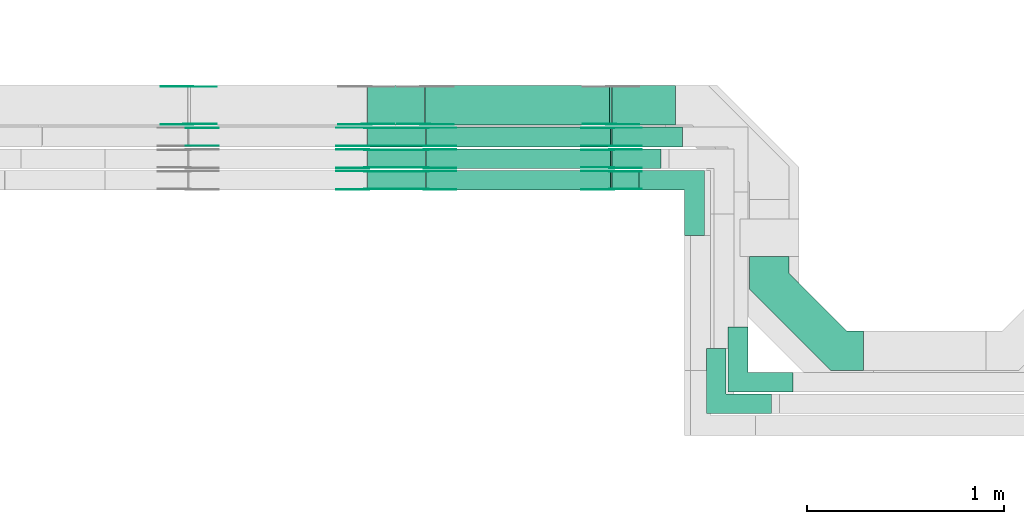
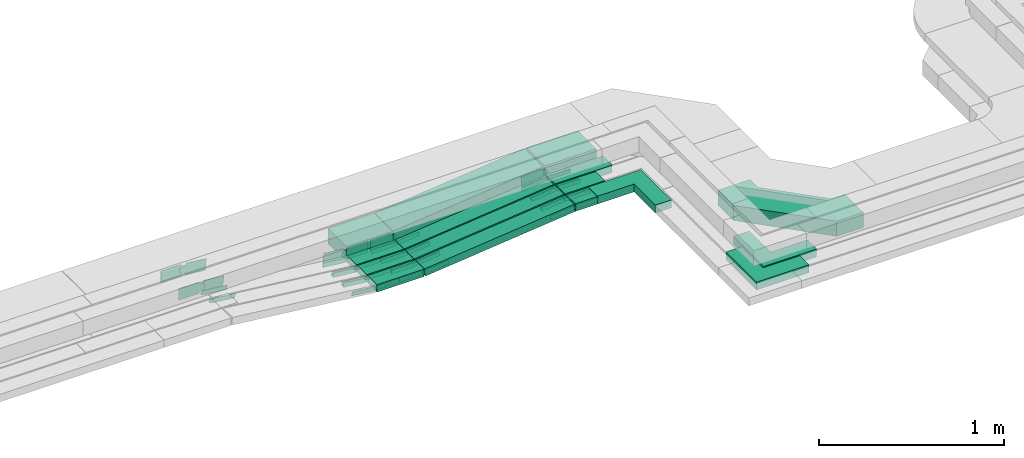
# One storey, part 19 of 33: 52 flow fittings, 12 flow segments.
"""IFC2X3 building model written with IfcOpenShell, lengths in millimetres."""

from ifc_helpers import new_model, entity, si_unit, converted_unit, derived_unit, direction, frame, frame_2d, origin, origin_2d_with_axis, place, context, subcontext, project, spatial, polyline, circle_curve, parameter, trimmed, segment, composite_curve, rectangle, outline, extrude, source, transform, mapped, material, type_object, type_shapes, element, save


model = new_model("IFC2X3")

# Units and contexts
model_context = context("Model", 3, precision=0.01, world=origin(), true_north=direction((6.12303176911189e-17, 1.0)))
body_context = subcontext(model_context, "Body", "Model", "MODEL_VIEW")
ifc_project = project(units=[si_unit("LENGTHUNIT", "METRE", prefix="MILLI"), si_unit("AREAUNIT", "SQUARE_METRE"), si_unit("VOLUMEUNIT", "CUBIC_METRE"), converted_unit("PLANEANGLEUNIT", "DEGREE", entity("IfcRatioMeasure", 0.0174532925199433), si_unit("PLANEANGLEUNIT", "RADIAN"), dimensions=[0, 0, 0, 0, 0, 0, 0]), si_unit("MASSUNIT", "GRAM", prefix="KILO"), derived_unit("MASSDENSITYUNIT", [(si_unit("MASSUNIT", "GRAM", prefix="KILO"), 1), (si_unit("LENGTHUNIT", "METRE"), -3)]), derived_unit("MOMENTOFINERTIAUNIT", [(si_unit("LENGTHUNIT", "METRE"), 4)]), si_unit("TIMEUNIT", "SECOND"), si_unit("FREQUENCYUNIT", "HERTZ"), si_unit("THERMODYNAMICTEMPERATUREUNIT", "DEGREE_CELSIUS"), derived_unit("THERMALTRANSMITTANCEUNIT", [(si_unit("MASSUNIT", "GRAM", prefix="KILO"), 1), (si_unit("THERMODYNAMICTEMPERATUREUNIT", "KELVIN"), -1), (si_unit("TIMEUNIT", "SECOND"), -3)]), derived_unit("VOLUMETRICFLOWRATEUNIT", [(si_unit("LENGTHUNIT", "METRE"), 3), (si_unit("TIMEUNIT", "SECOND"), -1)]), derived_unit("MASSFLOWRATEUNIT", [(si_unit("MASSUNIT", "GRAM", prefix="KILO"), 1), (si_unit("TIMEUNIT", "SECOND"), -1)]), derived_unit("ROTATIONALFREQUENCYUNIT", [(si_unit("TIMEUNIT", "SECOND"), -1)]), si_unit("ELECTRICCURRENTUNIT", "AMPERE"), si_unit("ELECTRICVOLTAGEUNIT", "VOLT"), si_unit("POWERUNIT", "WATT"), si_unit("FORCEUNIT", "NEWTON", prefix="KILO"), si_unit("ILLUMINANCEUNIT", "LUX"), si_unit("LUMINOUSFLUXUNIT", "LUMEN"), si_unit("LUMINOUSINTENSITYUNIT", "CANDELA"), derived_unit("USERDEFINED", [(si_unit("MASSUNIT", "GRAM", prefix="KILO"), -1), (si_unit("LENGTHUNIT", "METRE"), -2), (si_unit("TIMEUNIT", "SECOND"), 3), (si_unit("LUMINOUSFLUXUNIT", "LUMEN"), 1)]), derived_unit("LINEARVELOCITYUNIT", [(si_unit("LENGTHUNIT", "METRE"), 1), (si_unit("TIMEUNIT", "SECOND"), -1)]), si_unit("PRESSUREUNIT", "PASCAL"), derived_unit("USERDEFINED", [(si_unit("LENGTHUNIT", "METRE"), -2), (si_unit("MASSUNIT", "GRAM", prefix="KILO"), 1), (si_unit("TIMEUNIT", "SECOND"), -2)]), derived_unit("LINEARFORCEUNIT", [(si_unit("MASSUNIT", "GRAM", prefix="KILO"), 1), (si_unit("LENGTHUNIT", "METRE"), 1), (si_unit("TIMEUNIT", "SECOND"), -2), (si_unit("LENGTHUNIT", "METRE"), -1)]), derived_unit("PLANARFORCEUNIT", [(si_unit("MASSUNIT", "GRAM", prefix="KILO"), 1), (si_unit("LENGTHUNIT", "METRE"), 1), (si_unit("TIMEUNIT", "SECOND"), -2), (si_unit("LENGTHUNIT", "METRE"), -2)])], contexts=[model_context])

# Site, building, storey
site_placement = place(None, frame((0.0, -0.00077364408347762, 0.0)))
site = spatial("IfcSite", under=ifc_project, at=site_placement, CompositionType="ELEMENT")
building_placement = place(site_placement, origin())
building = spatial("IfcBuilding", under=site, at=building_placement, CompositionType="ELEMENT")
storey_placement = place(building_placement, frame((0.0, 0.0, 8100.0)))
storey = spatial("IfcBuildingStorey", under=building, at=storey_placement, CompositionType="ELEMENT", Elevation=8100.0)

# Flow segments
cable_carrier_segment_type = type_object("IfcCableCarrierSegmentType", PredefinedType="CABLETRAYSEGMENT")
flow_segment_1_placement = place(storey_placement, frame((42299.7266757616, 9974.9985534668, 2547.39498136109)))
element("IfcFlowSegment", 1, at=flow_segment_1_placement, inside=storey, type_object=cable_carrier_segment_type, context=body_context, shape_type="SweptSolid", body=[
    extrude(rectangle(XDim=321.461786684155, YDim=200.000000000002, at=frame_2d((0.0, -1.08713038571295e-12), x_axis=(1.0, 0.0))), frame((160.730893342077, 100.0, 0.0), z_axis=(0.0, 0.0, 1.0), x_axis=(-1.0, 0.0, 0.0)), (0.0, 0.0, 1.0), 99.9999999999989),
])
flow_segment_2_placement = place(storey_placement, frame((42299.9057283488, 9864.99855353356, 2544.9587837225)))
element("IfcFlowSegment", 2, at=flow_segment_2_placement, inside=storey, type_object=cable_carrier_segment_type, context=body_context, shape_type="SweptSolid", body=[
    extrude(rectangle(XDim=357.279766558546, YDim=99.9999998664901, at=frame_2d((-4.33431068813661e-12, 1.08357767203415e-12), x_axis=(1.0, 0.0))), frame((178.639882016923, 50.0, 0.0212370079798916), z_axis=(0.000118881671848944, 0.0, 0.999999992933574), x_axis=(-0.999999992933574, 0.0, 0.000118881671848944)), (0.0, 0.0, 1.0), 49.9999999332506),
])
flow_segment_3_placement = place(storey_placement, frame((42299.7266757616, 9754.9985534668, 2546.31908538351)))
element("IfcFlowSegment", 3, at=flow_segment_3_placement, inside=storey, type_object=cable_carrier_segment_type, context=body_context, shape_type="SweptSolid", body=[
    extrude(rectangle(XDim=247.461786684189, YDim=99.9999999999989, at=origin_2d_with_axis()), frame((123.730893342094, 50.0, 0.0), z_axis=(0.0, 0.0, 1.0), x_axis=(-1.0, 0.0, 0.0)), (0.0, 0.0, 1.0), 50.0000000000016),
])
flow_segment_4_placement = place(storey_placement, frame((41059.7844054956, 9644.99855346679, 2446.66940793269)))
element("IfcFlowSegment", 4, at=flow_segment_4_placement, inside=storey, type_object=cable_carrier_segment_type, context=body_context, shape_type="SweptSolid", body=[
    extrude(rectangle(XDim=294.865843634582, YDim=100.000000000001, at=origin_2d_with_axis()), frame((147.432921817291, 50.0, 0.0), z_axis=(0.0, 0.0, 1.0), x_axis=(-1.0, 0.0, 0.0)), (0.0, 0.0, 1.0), 50.0000000000016),
])
flow_segment_5_placement = place(storey_placement, frame((42299.7266757616, 9644.99855346679, 2546.66940793271)))
element("IfcFlowSegment", 5, at=flow_segment_5_placement, inside=storey, type_object=cable_carrier_segment_type, context=body_context, shape_type="SweptSolid", body=[
    extrude(rectangle(XDim=137.461786684197, YDim=100.000000000001, at=frame_2d((0.0, 1.08357767203415e-12), x_axis=(1.0, 0.0))), frame((68.7308933420983, 50.0, 0.0), z_axis=(0.0, 0.0, 1.0), x_axis=(-1.0, 0.0, 0.0)), (0.0, 0.0, 1.0), 49.9999999999995),
])
flow_segment_6_placement = place(storey_placement, frame((41357.0677822618, 9644.99855346682, 2447.07819267562)))
element("IfcFlowSegment", 6, at=flow_segment_6_placement, inside=storey, type_object=cable_carrier_segment_type, context=body_context, shape_type="SweptSolid", body=[
    extrude(rectangle(XDim=49.999999999999, YDim=100.000000000001, at=origin_2d_with_axis()), frame((2.64465136483404, 50.0, 24.8597228294773), z_axis=(0.994388913179111, 0.0, 0.105786054593537), x_axis=(-0.105786054593537, 0.0, 0.994388913179111)), (0.0, 0.0, 1.0), 940.227757215781),
])
flow_segment_7_placement = place(storey_placement, frame((41059.7844054956, 9754.99855346682, 2446.32300573429)))
element("IfcFlowSegment", 7, at=flow_segment_7_placement, inside=storey, type_object=cable_carrier_segment_type, context=body_context, shape_type="SweptSolid", body=[
    extrude(rectangle(XDim=294.902694932285, YDim=99.9999999999989, at=origin_2d_with_axis()), frame((147.451347466142, 50.0, 0.0), z_axis=(0.0, 0.0, 1.0), x_axis=(-1.0, 0.0, 0.0)), (0.0, 0.0, 1.0), 50.0000000000016),
])
flow_segment_8_placement = place(storey_placement, frame((41357.1046335595, 9754.99855346682, 2446.73179047722)))
element("IfcFlowSegment", 8, at=flow_segment_8_placement, inside=storey, type_object=cable_carrier_segment_type, context=body_context, shape_type="SweptSolid", body=[
    extrude(rectangle(XDim=49.9999999999999, YDim=99.9999999999989, at=origin_2d_with_axis()), frame((2.64465136483404, 50.0, 24.8597228294773), z_axis=(0.994388913179093, 0.0, 0.105786054593709), x_axis=(-0.105786054593709, 0.0, 0.994388913179093)), (0.0, 0.0, 1.0), 940.190697975519),
])
flow_segment_9_placement = place(storey_placement, frame((41059.5981585347, 9864.99855346682, 2444.98237905461)))
element("IfcFlowSegment", 9, at=flow_segment_9_placement, inside=storey, type_object=cable_carrier_segment_type, context=body_context, shape_type="SweptSolid", body=[
    extrude(rectangle(XDim=295.052090595501, YDim=99.9999999999989, at=origin_2d_with_axis()), frame((147.526045297751, 50.0, 0.0), z_axis=(0.0, 0.0, 1.0), x_axis=(-1.0, 0.0, 0.0)), (0.0, 0.0, 1.0), 50.0000000000016),
])
flow_segment_10_placement = place(storey_placement, frame((41357.0677822617, 9864.99855346682, 2445.39116379754)))
element("IfcFlowSegment", 10, at=flow_segment_10_placement, inside=storey, type_object=cable_carrier_segment_type, context=body_context, shape_type="SweptSolid", body=[
    extrude(rectangle(XDim=49.9999999999999, YDim=99.9999999999989, at=origin_2d_with_axis()), frame((2.64465136484271, 50.0, 24.8597228294751), z_axis=(0.994388913179093, 0.0, 0.105786054593709), x_axis=(-0.105786054593709, 0.0, 0.994388913179093)), (0.0, 0.0, 1.0), 940.407341948837),
])
flow_segment_11_placement = place(storey_placement, frame((41059.7844054956, 9974.99855346681, 2447.10630735317)))
element("IfcFlowSegment", 11, at=flow_segment_11_placement, inside=storey, type_object=cable_carrier_segment_type, context=body_context, shape_type="SweptSolid", body=[
    extrude(rectangle(XDim=289.500216036665, YDim=199.999999999998, at=origin_2d_with_axis()), frame((144.750108018333, 100.0, 0.0), z_axis=(0.0, 0.0, 1.0), x_axis=(-1.0, 0.0, 0.0)), (0.0, 0.0, 1.0), 99.9999999999989),
])
flow_segment_12_placement = place(storey_placement, frame((41351.7021546638, 9974.99855346681, 2447.79564643714)))
element("IfcFlowSegment", 12, at=flow_segment_12_placement, inside=storey, type_object=cable_carrier_segment_type, context=body_context, shape_type="SweptSolid", body=[
    extrude(rectangle(XDim=99.999999999998, YDim=199.999999999998, at=origin_2d_with_axis()), frame((5.28930272967675, 100.0, 49.7194456589545), z_axis=(0.994388913179111, 0.0, 0.105786054593537), x_axis=(-0.105786054593537, 0.0, 0.994388913179111)), (0.0, 0.0, 1.0), 940.304512766153),
])

# Flow fittings
ifc_material_1 = material()
cable_carrier_fitting_type_1 = type_object("IfcCableCarrierFittingType", Name="470_DKC_G5_Sheet horizontal bend:-", PredefinedType="NOTDEFINED", material=ifc_material_1)
shared_shape_1 = source(origin(), body_context, "Body", "SweptSolid", [
    extrude(outline(polyline([(-269.5, -306.499999999999), (-102.07864376269, -306.499999999999), (306.499999999999, 102.07864376269), (306.5, 269.499999999999), (106.5, 269.499999999999), (106.5, 184.921356237309), (-184.921356237309, -106.499999999999), (-269.5, -106.499999999999), (-269.5, -306.499999999999)])), frame((-206.499999999993, 206.499999999989, -50.0)), (0.0, 0.0, 1.0), 100.0),
])
type_shapes(cable_carrier_fitting_type_1, [shared_shape_1])
flow_fitting_placement = place(storey_placement, frame((43097.1884624458, 8832.6896027525, 2597.39498136109), z_axis=(0.0, 0.0, 1.0), x_axis=(0.0, -1.0, 0.0)))
element("IfcFlowFitting", 13, at=flow_fitting_placement, inside=storey, type_object=cable_carrier_fitting_type_1, material=ifc_material_1, Name="470_DKC_G5_Sheet horizontal bend:-", ObjectType="470_DKC_G5_Sheet horizontal bend:-", context=body_context, shape_type="MappedRepresentation", body=[
    mapped(shared_shape_1, transform((0.0, 0.0, 0.0), scale=1.0)),
])
cable_carrier_fitting_type_2 = type_object("IfcCableCarrierFittingType", Name="470_DKC_F5_Mesh horizontal angle:At right angles", PredefinedType="NOTDEFINED", material=ifc_material_1)
shared_shape_2 = source(origin(), body_context, "Body", "SweptSolid", [
    extrude(outline(polyline([(-143.333333333335, -143.333333333332), (186.666666666646, -143.333333333332), (186.666666666652, -43.3333333333317), (-43.3333333333294, -43.3333333333373), (-43.3333333333166, 186.666666666663), (-143.333333333317, 186.666666666669), (-143.333333333335, -143.333333333332)])), frame((-93.3333333333341, 93.3333333333192, -25.0), z_axis=(0.0, 0.0, 1.0), x_axis=(0.0, 1.0, 0.0)), (0.0, 0.0, 1.0), 51.9999999999999),
])
type_shapes(cable_carrier_fitting_type_2, [shared_shape_2])
for number, where, z_axis, x_axis, name in (
    (14, (42937.1884624458, 8672.68960275251, 2569.92549664435), (0.0, 0.0, 1.0), (0.0, -1.0, 0.0), "470_DKC_F5_Mesh horizontal angle:At right angles"),
    (15, (42827.1884624458, 8562.68960275251, 2571.31908538351), (0.0, 0.0, 1.0), (0.0, -1.0, 0.0), "470_DKC_F5_Mesh horizontal angle:At right angles"),
    (16, (42717.1884624458, 9694.9985534668, 2571.66940793271), (0.0, 0.0, 1.0), (0.0, 1.0, 0.0), "470_DKC_F5_Mesh horizontal angle:At right angles"),
):
    element("IfcFlowFitting", number, at=place(storey_placement, frame(where, z_axis=z_axis, x_axis=x_axis)), inside=storey, type_object=cable_carrier_fitting_type_2, material=ifc_material_1, Name=name, ObjectType="470_DKC_F5_Mesh horizontal angle:At right angles", context=body_context, shape_type="MappedRepresentation", body=[
        mapped(shared_shape_2, transform((0.0, 0.0, 0.0), scale=1.0)),
    ])
ifc_material_2 = material(Name="G")
cable_carrier_fitting_type_3 = type_object("IfcCableCarrierFittingType", PredefinedType="NOTDEFINED", material=ifc_material_2)
shared_shape_3 = source(origin(), body_context, "Body", "SweptSolid", [
    extrude(outline(composite_curve([segment(trimmed(circle_curve(frame_2d((-44.5901162790698, 0.0), x_axis=(1.0, 0.0)), 12.5), [parameter(90.0000000000007)], [parameter(270.0)], True, "PARAMETER"), True, "CONTINUOUS"), segment(polyline([(-44.5901162790697, -12.5), (-33.0901162790698, -12.5)]), True, "CONTINUOUS"), segment(polyline([(-33.0901162790698, -12.5), (-31.2296511627907, -14.5)]), True, "CONTINUOUS"), segment(polyline([(-31.2296511627907, -14.5), (108.90988372093, -14.5)]), True, "CONTINUOUS"), segment(polyline([(108.90988372093, -14.5), (108.90988372093, 14.5)]), True, "CONTINUOUS"), segment(polyline([(108.90988372093, 14.5), (-31.2296511627907, 14.5)]), True, "CONTINUOUS"), segment(polyline([(-31.2296511627907, 14.5), (-33.0901162790698, 12.5)]), True, "CONTINUOUS"), segment(polyline([(-33.0901162790698, 12.5), (-44.5901162790699, 12.5)]), True, "CONTINUOUS")], self_intersect=False)), frame((44.5901162790698, 0.0, 0.0), z_axis=(0.0, 0.0, -1.0), x_axis=(1.0, 0.0, 0.0)), (0.0, 0.0, -1.0), 2.0),
])
type_shapes(cable_carrier_fitting_type_3, [shared_shape_3])
for number, where, z_axis, x_axis in (
    (17, (42297.1884624458, 9649.53855345666, 2571.66940793272), (0.0, -1.0, 0.0), (-0.994388913179106, 0.0, -0.105786054593584)),
    (18, (41357.188462446, 9649.53855345666, 2471.66940793268), (0.0, -1.0, 0.0), (0.994388913179106, 0.0, 0.105786054593584)),
    (19, (41057.1884624458, 9740.45855347695, 2471.66940793268), (0.0, 1.0, 0.0), (-0.993961132894515, 0.0, 0.10973270385374)),
    (20, (41357.2253137437, 9759.53855345666, 2471.32300573428), (0.0, -1.0, 0.0), (0.994388913179106, 0.0, 0.105786054593584)),
    (21, (41057.1884624458, 9850.45855347697, 2471.32300573428), (0.0, 1.0, 0.0), (-0.993961132894515, 0.0, 0.10973270385374)),
    (22, (41357.188462446, 9869.53855345666, 2469.9823790546), (0.0, -1.0, 0.0), (0.994388913179106, 0.0, 0.105786054593584)),
    (23, (41057.0022154848, 9960.45855347698, 2469.9823790546), (0.0, 1.0, 0.0), (-0.993961132894515, 0.0, 0.10973270385374)),
    (24, (42297.1884624458, 9850.45855347697, 2571.31908538353), (0.0, 1.0, 0.0), (1.0, 0.0, 0.0)),
    (25, (42297.3687584532, 9960.45855347698, 2570.00155948099), (0.0, 1.0, 0.0), (0.999999992933574, 0.0, -0.000118881671840432)),
):
    element("IfcFlowFitting", number, at=place(storey_placement, frame(where, z_axis=z_axis, x_axis=x_axis)), inside=storey, type_object=cable_carrier_fitting_type_3, material=ifc_material_2, context=body_context, shape_type="MappedRepresentation", body=[
        mapped(shared_shape_3, transform((0.0, 0.0, 0.0), scale=1.0)),
    ])
cable_carrier_fitting_type_4 = type_object("IfcCableCarrierFittingType", PredefinedType="NOTDEFINED", material=ifc_material_2)
shared_shape_4 = source(origin(), body_context, "Body", "SweptSolid", [
    extrude(outline(composite_curve([segment(trimmed(circle_curve(frame_2d((-44.5901162790697, 0.0), x_axis=(1.0, 0.0)), 12.5), [parameter(90.0000000000007)], [parameter(270.0)], True, "PARAMETER"), True, "CONTINUOUS"), segment(polyline([(-44.5901162790697, -12.5), (-33.0901162790697, -12.5)]), True, "CONTINUOUS"), segment(polyline([(-33.0901162790697, -12.5), (-31.2296511627907, -14.5)]), True, "CONTINUOUS"), segment(polyline([(-31.2296511627907, -14.5), (108.90988372093, -14.5)]), True, "CONTINUOUS"), segment(polyline([(108.90988372093, -14.5), (108.90988372093, 14.5)]), True, "CONTINUOUS"), segment(polyline([(108.90988372093, 14.5), (-31.2296511627907, 14.5)]), True, "CONTINUOUS"), segment(polyline([(-31.2296511627907, 14.5), (-33.0901162790698, 12.5)]), True, "CONTINUOUS"), segment(polyline([(-33.0901162790698, 12.5), (-44.5901162790699, 12.5)]), True, "CONTINUOUS")], self_intersect=False)), frame((44.5901162790697, 0.0, 0.0)), (0.0, 0.0, 1.0), 2.0),
])
type_shapes(cable_carrier_fitting_type_4, [shared_shape_4])
for number, where, z_axis, x_axis in (
    (26, (42297.1884624458, 9740.45855347698, 2571.66940793273), (0.0, 1.0, 0.0), (-0.994388913179106, 0.0, -0.105786054593584)),
    (27, (41357.188462446, 9740.45855347698, 2471.66940793267), (0.0, 1.0, 0.0), (0.994388913179106, 0.0, 0.105786054593584)),
    (28, (41057.1884624458, 9649.53855345663, 2471.66940793268), (0.0, -1.0, 0.0), (-0.993961132894515, 0.0, 0.10973270385374)),
    (29, (41357.2253137437, 9850.45855347698, 2471.32300573428), (0.0, 1.0, 0.0), (0.994388913179106, 0.0, 0.105786054593584)),
    (30, (41057.1884624458, 9759.53855345666, 2471.32300573428), (0.0, -1.0, 0.0), (-0.993961132894515, 0.0, 0.10973270385374)),
    (31, (41357.188462446, 9960.45855347698, 2469.9823790546), (0.0, 1.0, 0.0), (0.994388913179106, 0.0, 0.105786054593584)),
    (32, (41057.0022154848, 9869.53855345666, 2469.9823790546), (0.0, -1.0, 0.0), (-0.993961132894515, 0.0, 0.10973270385374)),
    (33, (42297.1884624458, 9759.53855345666, 2571.31908538354), (0.0, -1.0, 0.0), (1.0, 0.0, 0.0)),
    (34, (42297.3687584532, 9869.53855345666, 2570.00155948099), (0.0, -1.0, 0.0), (0.999999992933574, 0.0, -0.000118881671840432)),
):
    element("IfcFlowFitting", number, at=place(storey_placement, frame(where, z_axis=z_axis, x_axis=x_axis)), inside=storey, type_object=cable_carrier_fitting_type_4, material=ifc_material_2, context=body_context, shape_type="MappedRepresentation", body=[
        mapped(shared_shape_4, transform((0.0, 0.0, 0.0), scale=1.0)),
    ])
cable_carrier_fitting_type_5 = type_object("IfcCableCarrierFittingType", PredefinedType="NOTDEFINED", material=ifc_material_2)
shared_shape_5 = source(origin(), body_context, "Body", "SweptSolid", [
    extrude(outline(composite_curve([segment(trimmed(circle_curve(frame_2d((-44.5901162790698, 0.0), x_axis=(1.0, 0.0)), 12.5), [parameter(90.0000000000007)], [parameter(270.0)], True, "PARAMETER"), True, "CONTINUOUS"), segment(polyline([(-44.5901162790697, -12.5), (-33.0901162790698, -12.5)]), True, "CONTINUOUS"), segment(polyline([(-33.0901162790698, -12.5), (-31.2296511627907, -14.5)]), True, "CONTINUOUS"), segment(polyline([(-31.2296511627907, -14.5), (108.90988372093, -14.5)]), True, "CONTINUOUS"), segment(polyline([(108.90988372093, -14.5), (108.90988372093, 14.5)]), True, "CONTINUOUS"), segment(polyline([(108.90988372093, 14.5), (-31.2296511627907, 14.5)]), True, "CONTINUOUS"), segment(polyline([(-31.2296511627907, 14.5), (-33.0901162790698, 12.5)]), True, "CONTINUOUS"), segment(polyline([(-33.0901162790698, 12.5), (-44.5901162790699, 12.5)]), True, "CONTINUOUS")], self_intersect=False)), frame((44.5901162790698, 0.0, 0.0), z_axis=(0.0, 0.0, -1.0), x_axis=(1.0, 0.0, 0.0)), (0.0, 0.0, -1.0), 2.0),
])
type_shapes(cable_carrier_fitting_type_5, [shared_shape_5])
for number, where, z_axis, x_axis in (
    (35, (42297.1884624458, 9738.45855347698, 2571.66940793272), (0.0, 1.0, 0.0), (1.0, 0.0, 0.0)),
    (36, (41357.188462446, 9738.45855347698, 2471.66940793268), (0.0, 1.0, 0.0), (-1.0, 0.0, 0.0)),
    (37, (41057.1884624457, 9651.53855345663, 2471.66940793269), (0.0, -1.0, 0.0), (1.0, 0.0, 0.0)),
    (38, (41357.2253137437, 9848.45855347698, 2471.32300573428), (0.0, 1.0, 0.0), (-1.0, 0.0, 0.0)),
    (39, (41057.1884624457, 9761.53855345666, 2471.32300573428), (0.0, -1.0, 0.0), (1.0, 0.0, 0.0)),
    (40, (41357.188462446, 9958.45855347698, 2469.9823790546), (0.0, 1.0, 0.0), (-1.0, 0.0, 0.0)),
    (41, (41057.0022154848, 9871.53855345666, 2469.9823790546), (0.0, -1.0, 0.0), (1.0, 0.0, 0.0)),
    (42, (42297.1884624458, 9761.53855345666, 2571.31908538353), (0.0, -1.0, 0.0), (-0.994388913179106, 0.0, -0.105786054593578)),
    (43, (40151.7153602834, 9958.45855347698, 2569.92549664436), (0.0, 1.0, 0.0), (0.993961132894516, 0.0, -0.109732703853733)),
    (44, (42297.3687584532, 9871.53855345666, 2570.00155948099), (0.0, -1.0, 0.0), (-0.994388913179107, 0.0, -0.105786054593577)),
):
    element("IfcFlowFitting", number, at=place(storey_placement, frame(where, z_axis=z_axis, x_axis=x_axis)), inside=storey, type_object=cable_carrier_fitting_type_5, material=ifc_material_2, context=body_context, shape_type="MappedRepresentation", body=[
        mapped(shared_shape_5, transform((0.0, 0.0, 0.0), scale=1.0)),
    ])
cable_carrier_fitting_type_6 = type_object("IfcCableCarrierFittingType", PredefinedType="NOTDEFINED", material=ifc_material_2)
shared_shape_6 = source(origin(), body_context, "Body", "SweptSolid", [
    extrude(outline(composite_curve([segment(trimmed(circle_curve(frame_2d((-44.5901162790697, 0.0), x_axis=(1.0, 0.0)), 12.5), [parameter(90.0000000000007)], [parameter(270.0)], True, "PARAMETER"), True, "CONTINUOUS"), segment(polyline([(-44.5901162790697, -12.5), (-33.0901162790697, -12.5)]), True, "CONTINUOUS"), segment(polyline([(-33.0901162790697, -12.5), (-31.2296511627907, -14.5)]), True, "CONTINUOUS"), segment(polyline([(-31.2296511627907, -14.5), (108.90988372093, -14.5)]), True, "CONTINUOUS"), segment(polyline([(108.90988372093, -14.5), (108.90988372093, 14.5)]), True, "CONTINUOUS"), segment(polyline([(108.90988372093, 14.5), (-31.2296511627907, 14.5)]), True, "CONTINUOUS"), segment(polyline([(-31.2296511627907, 14.5), (-33.0901162790698, 12.5)]), True, "CONTINUOUS"), segment(polyline([(-33.0901162790698, 12.5), (-44.5901162790699, 12.5)]), True, "CONTINUOUS")], self_intersect=False)), frame((44.5901162790697, 0.0, 0.0)), (0.0, 0.0, 1.0), 2.0),
])
type_shapes(cable_carrier_fitting_type_6, [shared_shape_6])
for number, where, z_axis, x_axis in (
    (45, (42297.1884624458, 9651.53855345666, 2571.66940793272), (0.0, -1.0, 0.0), (1.0, 0.0, 0.0)),
    (46, (41357.188462446, 9651.53855345667, 2471.66940793268), (0.0, -1.0, 0.0), (-1.0, 0.0, 0.0)),
    (47, (41057.1884624457, 9738.45855347694, 2471.66940793269), (0.0, 1.0, 0.0), (1.0, 0.0, 0.0)),
    (48, (41357.2253137437, 9761.53855345666, 2471.32300573429), (0.0, -1.0, 0.0), (-1.0, 0.0, 0.0)),
    (49, (41057.1884624457, 9848.45855347697, 2471.32300573429), (0.0, 1.0, 0.0), (1.0, 0.0, 0.0)),
    (50, (41357.188462446, 9871.53855345667, 2469.98237905461), (0.0, -1.0, 0.0), (-1.0, 0.0, 0.0)),
    (51, (41057.0022154848, 9958.45855347698, 2469.98237905461), (0.0, 1.0, 0.0), (1.0, 0.0, 0.0)),
    (52, (42297.1884624458, 9848.45855347697, 2571.31908538353), (0.0, 1.0, 0.0), (-0.994388913179106, 0.0, -0.105786054593578)),
    (53, (40151.7153602834, 9871.53855345667, 2569.92549664436), (0.0, -1.0, 0.0), (0.993961132894516, 0.0, -0.109732703853733)),
    (54, (42297.3687584532, 9958.45855347698, 2570.00155948099), (0.0, 1.0, 0.0), (-0.994388913179107, 0.0, -0.105786054593577)),
):
    element("IfcFlowFitting", number, at=place(storey_placement, frame(where, z_axis=z_axis, x_axis=x_axis)), inside=storey, type_object=cable_carrier_fitting_type_6, material=ifc_material_2, context=body_context, shape_type="MappedRepresentation", body=[
        mapped(shared_shape_6, transform((0.0, 0.0, 0.0), scale=1.0)),
    ])
cable_carrier_fitting_type_7 = type_object("IfcCableCarrierFittingType", PredefinedType="NOTDEFINED", material=ifc_material_2)
shared_shape_7 = source(origin(), body_context, "Body", "SweptSolid", [
    extrude(outline(composite_curve([segment(trimmed(circle_curve(frame_2d((-41.4651162790697, 0.0), x_axis=(1.0, 0.0)), 25.0), [parameter(90.0000000000007)], [parameter(270.0)], True, "PARAMETER"), True, "CONTINUOUS"), segment(polyline([(-41.4651162790697, -25.0), (-29.9651162790697, -25.0)]), True, "CONTINUOUS"), segment(polyline([(-29.9651162790697, -25.0), (-28.1046511627907, -38.5)]), True, "CONTINUOUS"), segment(polyline([(-28.1046511627907, -38.5), (99.5348837209303, -38.5)]), True, "CONTINUOUS"), segment(polyline([(99.5348837209303, -38.5), (99.5348837209303, 38.5)]), True, "CONTINUOUS"), segment(polyline([(99.5348837209303, 38.5), (-28.1046511627907, 38.5)]), True, "CONTINUOUS"), segment(polyline([(-28.1046511627907, 38.5), (-29.9651162790697, 25.0)]), True, "CONTINUOUS"), segment(polyline([(-29.9651162790697, 25.0), (-41.46511627907, 25.0)]), True, "CONTINUOUS")], self_intersect=False)), frame((41.4651162790697, 0.0, 0.0), z_axis=(0.0, 0.0, -1.0), x_axis=(1.0, 0.0, 0.0)), (0.0, 0.0, -1.0), 2.0),
])
type_shapes(cable_carrier_fitting_type_7, [shared_shape_7])
for number, where, z_axis, x_axis in (
    (55, (41353.14888081, 9979.53855345665, 2497.10630735315), (0.0, -1.0, 0.0), (0.994388913179106, 0.0, 0.105786054593584)),
    (56, (40153.1119058377, 9979.53855345665, 2596.76391980056), (0.0, -1.0, 0.0), (-0.99999998513436, 0.0, 0.00017242761067629)),
):
    element("IfcFlowFitting", number, at=place(storey_placement, frame(where, z_axis=z_axis, x_axis=x_axis)), inside=storey, type_object=cable_carrier_fitting_type_7, material=ifc_material_2, context=body_context, shape_type="MappedRepresentation", body=[
        mapped(shared_shape_7, transform((0.0, 0.0, 0.0), scale=1.0)),
    ])
cable_carrier_fitting_type_8 = type_object("IfcCableCarrierFittingType", PredefinedType="NOTDEFINED", material=ifc_material_2)
shared_shape_8 = source(origin(), body_context, "Body", "SweptSolid", [
    extrude(outline(composite_curve([segment(trimmed(circle_curve(frame_2d((-41.4651162790697, 0.0), x_axis=(1.0, 0.0)), 25.0), [parameter(90.0000000000007)], [parameter(270.0)], True, "PARAMETER"), True, "CONTINUOUS"), segment(polyline([(-41.4651162790697, -25.0), (-29.9651162790697, -25.0)]), True, "CONTINUOUS"), segment(polyline([(-29.9651162790697, -25.0), (-28.1046511627907, -38.5)]), True, "CONTINUOUS"), segment(polyline([(-28.1046511627907, -38.5), (99.5348837209303, -38.5)]), True, "CONTINUOUS"), segment(polyline([(99.5348837209303, -38.5), (99.5348837209303, 38.5)]), True, "CONTINUOUS"), segment(polyline([(99.5348837209303, 38.5), (-28.1046511627907, 38.5)]), True, "CONTINUOUS"), segment(polyline([(-28.1046511627907, 38.5), (-29.9651162790697, 25.0)]), True, "CONTINUOUS"), segment(polyline([(-29.9651162790697, 25.0), (-41.46511627907, 25.0)]), True, "CONTINUOUS")], self_intersect=False)), frame((41.4651162790697, 0.0, 0.0)), (0.0, 0.0, 1.0), 2.0),
])
type_shapes(cable_carrier_fitting_type_8, [shared_shape_8])
for number, where, z_axis, x_axis in (
    (57, (41055.8126494717, 9979.53855345665, 2497.10630735315), (0.0, -1.0, 0.0), (-0.993961132894515, 0.0, 0.10973270385374)),
    (58, (42295.8624164839, 9979.53855345665, 2597.39498136111), (0.0, -1.0, 0.0), (1.0, 0.0, 0.0)),
    (59, (40153.1119058377, 10170.458553477, 2596.76391980056), (0.0, 1.0, 0.0), (-0.99999998513436, 0.0, 0.00017242761067629)),
):
    element("IfcFlowFitting", number, at=place(storey_placement, frame(where, z_axis=z_axis, x_axis=x_axis)), inside=storey, type_object=cable_carrier_fitting_type_8, material=ifc_material_2, context=body_context, shape_type="MappedRepresentation", body=[
        mapped(shared_shape_8, transform((0.0, 0.0, 0.0), scale=1.0)),
    ])
cable_carrier_fitting_type_9 = type_object("IfcCableCarrierFittingType", PredefinedType="NOTDEFINED", material=ifc_material_2)
shared_shape_9 = source(origin(), body_context, "Body", "SweptSolid", [
    extrude(outline(composite_curve([segment(trimmed(circle_curve(frame_2d((-41.4651162790697, 0.0), x_axis=(1.0, 0.0)), 25.0), [parameter(90.0000000000007)], [parameter(270.0)], True, "PARAMETER"), True, "CONTINUOUS"), segment(polyline([(-41.4651162790697, -25.0), (-29.9651162790697, -25.0)]), True, "CONTINUOUS"), segment(polyline([(-29.9651162790697, -25.0), (-28.1046511627907, -38.5)]), True, "CONTINUOUS"), segment(polyline([(-28.1046511627907, -38.5), (99.5348837209303, -38.5)]), True, "CONTINUOUS"), segment(polyline([(99.5348837209303, -38.5), (99.5348837209303, 38.5)]), True, "CONTINUOUS"), segment(polyline([(99.5348837209303, 38.5), (-28.1046511627907, 38.5)]), True, "CONTINUOUS"), segment(polyline([(-28.1046511627907, 38.5), (-29.9651162790697, 25.0)]), True, "CONTINUOUS"), segment(polyline([(-29.9651162790697, 25.0), (-41.46511627907, 25.0)]), True, "CONTINUOUS")], self_intersect=False)), frame((41.4651162790697, 0.0, 0.0), z_axis=(0.0, 0.0, -1.0), x_axis=(1.0, 0.0, 0.0)), (0.0, 0.0, -1.0), 2.0),
])
type_shapes(cable_carrier_fitting_type_9, [shared_shape_9])
for number, where, z_axis, x_axis in (
    (60, (41055.8126494717, 9981.53855345665, 2497.10630735316), (0.0, -1.0, 0.0), (1.0, 0.0, 0.0)),
    (61, (42295.8624164839, 9981.53855345665, 2597.39498136111), (0.0, -1.0, 0.0), (-0.994388913179106, 0.0, -0.105786054593579)),
    (62, (40153.1119058377, 10168.458553477, 2596.76391980055), (0.0, 1.0, 0.0), (0.993961132894515, 0.0, -0.109732703853739)),
):
    element("IfcFlowFitting", number, at=place(storey_placement, frame(where, z_axis=z_axis, x_axis=x_axis)), inside=storey, type_object=cable_carrier_fitting_type_9, material=ifc_material_2, context=body_context, shape_type="MappedRepresentation", body=[
        mapped(shared_shape_9, transform((0.0, 0.0, 0.0), scale=1.0)),
    ])
cable_carrier_fitting_type_10 = type_object("IfcCableCarrierFittingType", PredefinedType="NOTDEFINED", material=ifc_material_2)
shared_shape_10 = source(origin(), body_context, "Body", "SweptSolid", [
    extrude(outline(composite_curve([segment(trimmed(circle_curve(frame_2d((-41.4651162790697, 0.0), x_axis=(1.0, 0.0)), 25.0), [parameter(90.0000000000007)], [parameter(270.0)], True, "PARAMETER"), True, "CONTINUOUS"), segment(polyline([(-41.4651162790697, -25.0), (-29.9651162790697, -25.0)]), True, "CONTINUOUS"), segment(polyline([(-29.9651162790697, -25.0), (-28.1046511627907, -38.5)]), True, "CONTINUOUS"), segment(polyline([(-28.1046511627907, -38.5), (99.5348837209303, -38.5)]), True, "CONTINUOUS"), segment(polyline([(99.5348837209303, -38.5), (99.5348837209303, 38.5)]), True, "CONTINUOUS"), segment(polyline([(99.5348837209303, 38.5), (-28.1046511627907, 38.5)]), True, "CONTINUOUS"), segment(polyline([(-28.1046511627907, 38.5), (-29.9651162790697, 25.0)]), True, "CONTINUOUS"), segment(polyline([(-29.9651162790697, 25.0), (-41.46511627907, 25.0)]), True, "CONTINUOUS")], self_intersect=False)), frame((41.4651162790697, 0.0, 0.0)), (0.0, 0.0, 1.0), 2.0),
])
type_shapes(cable_carrier_fitting_type_10, [shared_shape_10])
for number, where, z_axis, x_axis in (
    (63, (41353.14888081, 9981.53855345665, 2497.10630735316), (0.0, -1.0, 0.0), (-1.0, 0.0, 0.0)),
    (64, (40153.1119058377, 9981.53855345665, 2596.76391980055), (0.0, -1.0, 0.0), (0.993961132894515, 0.0, -0.109732703853739)),
):
    element("IfcFlowFitting", number, at=place(storey_placement, frame(where, z_axis=z_axis, x_axis=x_axis)), inside=storey, type_object=cable_carrier_fitting_type_10, material=ifc_material_2, context=body_context, shape_type="MappedRepresentation", body=[
        mapped(shared_shape_10, transform((0.0, 0.0, 0.0), scale=1.0)),
    ])

save(model, "model.ifc")
